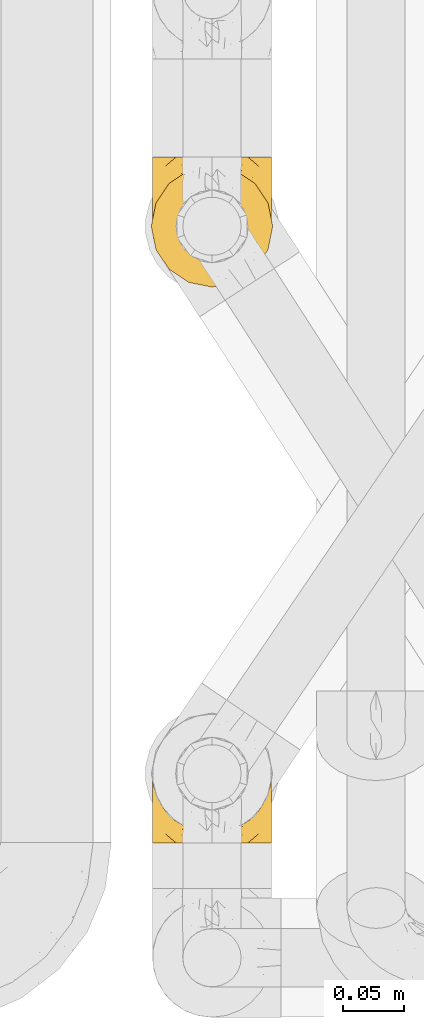
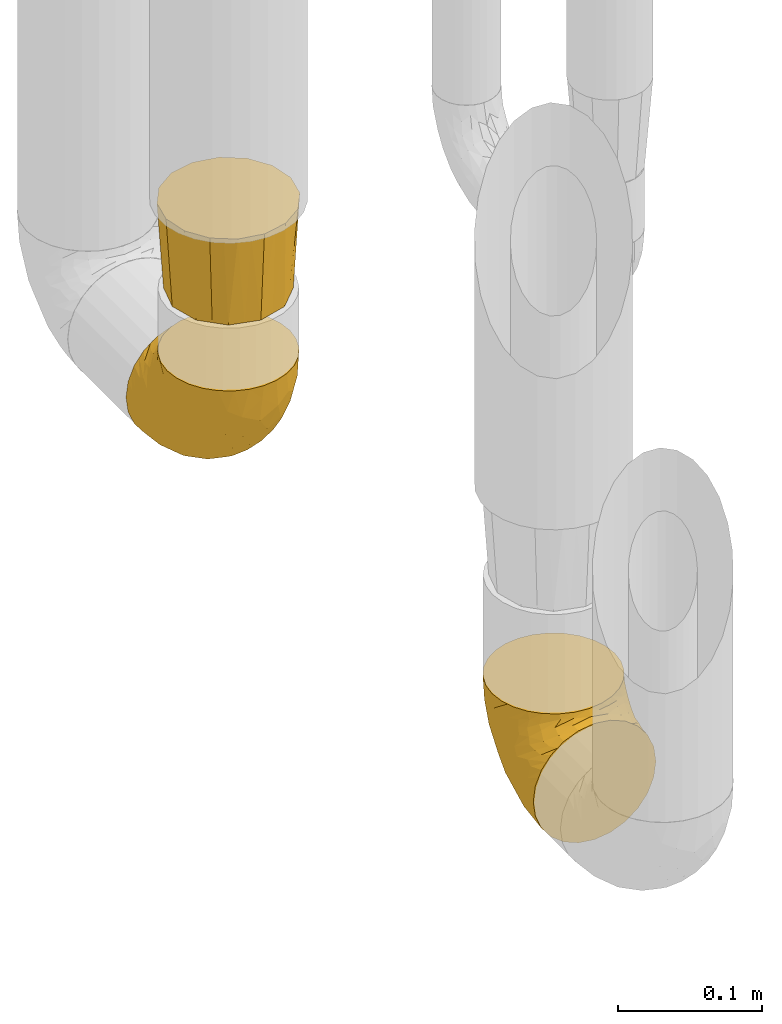
# One storey, part 380 of 827: 3 coverings.
"""IFC2X3 building model written with IfcOpenShell, lengths in millimetres."""

from ifc_helpers import new_model, entity, si_unit, converted_unit, derived_unit, direction, frame, origin, place, context, subcontext, project, spatial, faceted_brep, element, save


model = new_model("IFC2X3")

# Units and contexts
model_context = context("Model", 3, precision=0.01, world=origin(), true_north=direction((6.12303176911189e-17, 1.0)))
body_context = subcontext(model_context, "Body", "Model", "MODEL_VIEW")
ifc_project = project(units=[si_unit("LENGTHUNIT", "METRE", prefix="MILLI"), si_unit("AREAUNIT", "SQUARE_METRE"), si_unit("VOLUMEUNIT", "CUBIC_METRE"), converted_unit("PLANEANGLEUNIT", "DEGREE", entity("IfcRatioMeasure", 0.0174532925199433), si_unit("PLANEANGLEUNIT", "RADIAN"), dimensions=[0, 0, 0, 0, 0, 0, 0]), si_unit("MASSUNIT", "GRAM", prefix="KILO"), derived_unit("MASSDENSITYUNIT", [(si_unit("MASSUNIT", "GRAM", prefix="KILO"), 1), (si_unit("LENGTHUNIT", "METRE"), -3)]), derived_unit("MOMENTOFINERTIAUNIT", [(si_unit("LENGTHUNIT", "METRE"), 4)]), si_unit("TIMEUNIT", "SECOND"), si_unit("FREQUENCYUNIT", "HERTZ"), si_unit("THERMODYNAMICTEMPERATUREUNIT", "DEGREE_CELSIUS"), derived_unit("THERMALTRANSMITTANCEUNIT", [(si_unit("MASSUNIT", "GRAM", prefix="KILO"), 1), (si_unit("THERMODYNAMICTEMPERATUREUNIT", "KELVIN"), -1), (si_unit("TIMEUNIT", "SECOND"), -3)]), derived_unit("VOLUMETRICFLOWRATEUNIT", [(si_unit("LENGTHUNIT", "METRE"), 3), (si_unit("TIMEUNIT", "SECOND"), -1)]), derived_unit("MASSFLOWRATEUNIT", [(si_unit("MASSUNIT", "GRAM", prefix="KILO"), 1), (si_unit("TIMEUNIT", "SECOND"), -1)]), derived_unit("ROTATIONALFREQUENCYUNIT", [(si_unit("TIMEUNIT", "SECOND"), -1)]), si_unit("ELECTRICCURRENTUNIT", "AMPERE"), si_unit("ELECTRICVOLTAGEUNIT", "VOLT"), si_unit("POWERUNIT", "WATT"), si_unit("FORCEUNIT", "NEWTON", prefix="KILO"), si_unit("ILLUMINANCEUNIT", "LUX"), si_unit("LUMINOUSFLUXUNIT", "LUMEN"), si_unit("LUMINOUSINTENSITYUNIT", "CANDELA"), derived_unit("USERDEFINED", [(si_unit("MASSUNIT", "GRAM", prefix="KILO"), -1), (si_unit("LENGTHUNIT", "METRE"), -2), (si_unit("TIMEUNIT", "SECOND"), 3), (si_unit("LUMINOUSFLUXUNIT", "LUMEN"), 1)]), derived_unit("LINEARVELOCITYUNIT", [(si_unit("LENGTHUNIT", "METRE"), 1), (si_unit("TIMEUNIT", "SECOND"), -1)]), si_unit("PRESSUREUNIT", "PASCAL"), derived_unit("USERDEFINED", [(si_unit("LENGTHUNIT", "METRE"), -2), (si_unit("MASSUNIT", "GRAM", prefix="KILO"), 1), (si_unit("TIMEUNIT", "SECOND"), -2)]), derived_unit("LINEARFORCEUNIT", [(si_unit("MASSUNIT", "GRAM", prefix="KILO"), 1), (si_unit("LENGTHUNIT", "METRE"), 1), (si_unit("TIMEUNIT", "SECOND"), -2), (si_unit("LENGTHUNIT", "METRE"), -1)]), derived_unit("PLANARFORCEUNIT", [(si_unit("MASSUNIT", "GRAM", prefix="KILO"), 1), (si_unit("LENGTHUNIT", "METRE"), 1), (si_unit("TIMEUNIT", "SECOND"), -2), (si_unit("LENGTHUNIT", "METRE"), -2)])], contexts=[model_context])

# Site, building, storey
site_placement = place(None, origin())
site = spatial("IfcSite", under=ifc_project, at=site_placement, CompositionType="ELEMENT")
building_placement = place(site_placement, origin())
building = spatial("IfcBuilding", under=site, at=building_placement, CompositionType="ELEMENT")
storey_placement = place(building_placement, frame((0.0, 0.0, 28200.0)))
storey = spatial("IfcBuildingStorey", under=building, at=storey_placement, Name="08", CompositionType="ELEMENT", Elevation=28200.0)

# Coverings
covering_1_placement = place(storey_placement, frame((46642.04, 14188.78, 349.25)))
element("IfcCovering", 1, at=covering_1_placement, inside=storey, Name=":ADSK_", ObjectType=":ADSK_", PredefinedType="INSULATION", context=body_context, shape_type="Brep", body=[
    faceted_brep([(1.6, 50.75, 107.75), (2.83, 39.8, 107.75), (6.47, 29.41, 107.75), (12.32, 20.09, 107.75), (20.11, 12.31, 107.75), (29.43, 6.46, 107.75), (39.81, 2.83, 107.75), (50.75, 1.6, 107.75), (61.69, 2.83, 107.75), (72.08, 6.47, 107.75), (81.4, 12.32, 107.75), (89.18, 20.11, 107.75), (95.03, 29.43, 107.75), (98.66, 39.81, 107.75), (99.9, 50.75, 107.75), (99.25, 56.45, 107.75), (98.66, 61.69, 107.75), (96.84, 66.88, 107.75), (95.02, 72.08, 107.75), (89.17, 81.4, 107.75), (81.38, 89.18, 107.75), (72.06, 95.03, 107.75), (61.68, 98.66, 107.75), (50.75, 99.9, 107.75), (39.8, 98.66, 107.75), (29.41, 95.02, 107.75), (20.09, 89.17, 107.75), (12.31, 81.38, 107.75), (6.46, 72.06, 107.75), (4.64, 66.87, 107.75), (2.83, 61.68, 107.75), (2.24, 56.45, 107.75), (1.92, 53.6, 107.75), (63.47, 107.75, 98.22), (75.32, 107.75, 93.31), (80.41, 107.75, 89.4), (85.5, 107.75, 85.5), (89.4, 107.75, 80.41), (93.31, 107.75, 75.32), (95.77, 107.75, 69.39), (98.22, 107.75, 63.47), (99.14, 107.75, 56.48), (99.52, 107.75, 53.61), (99.9, 107.75, 50.75), (98.22, 107.75, 38.02), (93.31, 107.75, 26.17), (85.5, 107.75, 15.99), (75.32, 107.75, 8.18), (63.47, 107.75, 3.27), (50.75, 107.75, 1.6), (38.02, 107.75, 3.27), (26.17, 107.75, 8.18), (15.99, 107.75, 15.99), (8.18, 107.75, 26.17), (3.27, 107.75, 38.02), (1.6, 107.75, 50.75), (2.35, 107.75, 56.48), (3.27, 107.75, 63.47), (5.73, 107.75, 69.39), (8.18, 107.75, 75.32), (12.09, 107.75, 80.41), (15.99, 107.75, 85.5), (21.08, 107.75, 89.4), (26.17, 107.75, 93.31), (38.02, 107.75, 98.22), (50.75, 107.75, 99.9), (42.18, 39.38, 27.53), (28.42, 49.75, 25.32), (37.78, 57.38, 16.29), (50.75, 74.94, 6.79), (42.85, 85.97, 4.51), (50.75, 95.66, 3.51), (24.75, 67.82, 17.47), (33.81, 83.09, 7.6), (22.57, 89.16, 12.27), (7.18, 37.01, 70.89), (2.73, 43.46, 87.17), (3.09, 51.79, 67.3), (6.92, 85.58, 31.65), (11.58, 62.84, 33.58), (5.17, 62.77, 47.23), (2.71, 88.17, 43.26), (1.6, 85.93, 55.08), (1.6, 91.42, 53.99), (1.6, 96.91, 52.9), (1.6, 99.62, 52.36), (1.6, 102.33, 51.82), (14.18, 82.57, 21.5), (5.88, 32.75, 89.94), (41.06, 13.79, 60.45), (36.25, 6.77, 83.0), (28.62, 16.46, 64.79), (1.6, 55.08, 85.93), (1.6, 58.17, 81.31), (1.6, 61.26, 76.69), (1.6, 64.35, 72.06), (1.6, 67.44, 67.44), (10.85, 24.18, 88.74), (38.35, 23.37, 45.98), (9.6, 49.76, 47.13), (26.24, 9.84, 89.4), (50.75, 3.51, 95.66), (19.31, 55.75, 28.5), (16.41, 42.34, 42.81), (24.56, 37.78, 38.28), (50.75, 21.87, 45.35), (50.75, 33.61, 33.61), (18.47, 17.1, 82.57), (1.6, 51.28, 105.04), (1.6, 51.82, 102.33), (1.6, 52.9, 96.91), (1.6, 53.99, 91.42), (14.36, 28.01, 65.92), (20.64, 28.99, 53.11), (2.32, 69.9, 54.37), (50.75, 6.79, 74.94), (1.6, 72.06, 64.35), (1.6, 76.69, 61.26), (1.6, 81.31, 58.17), (50.75, 45.35, 21.87), (33.88, 34.79, 34.79), (29.24, 25.72, 48.48), (50.75, 14.33, 60.15), (50.75, 60.15, 14.33), (2.8, 62.38, 99.07), (2.48, 100.57, 60.55), (2.7, 91.06, 64.18), (3.2, 97.66, 64.36), (32.98, 97.55, 103.17), (24.67, 93.65, 101.69), (2.95, 66.85, 87.75), (2.19, 61.93, 89.38), (17.92, 101.4, 88.34), (12.02, 100.07, 82.14), (25.73, 101.36, 94.51), (16.63, 95.94, 89.64), (25.6, 96.3, 98.41), (36.72, 101.98, 99.71), (10.66, 85.88, 89.37), (6.87, 78.88, 88.21), (11.12, 82.8, 95.2), (10.31, 102.58, 79.14), (12.84, 82.88, 101.22), (17.38, 88.57, 99.41), (9.74, 88.67, 84.72), (4.63, 69.08, 97.47), (50.75, 102.19, 102.19), (42.52, 100.06, 104.02), (3.12, 70.56, 82.66), (17.58, 91.07, 95.42), (3.97, 77.56, 78.67), (5.94, 96.59, 72.69), (2.73, 86.38, 66.46), (6.23, 91.79, 75.3), (3.45, 81.71, 72.74), (10.84, 94.11, 82.93), (7.98, 76.09, 99.27), (7.33, 76.91, 93.51), (2.39, 81.44, 67.35), (75.76, 101.37, 94.51), (90.65, 94.12, 82.94), (83.57, 101.41, 88.33), (84.85, 95.96, 89.64), (71.05, 96.22, 103.62), (98.54, 66.85, 87.74), (99.3, 61.94, 89.38), (99.9, 58.17, 81.31), (96.86, 69.1, 97.47), (84.1, 88.58, 99.41), (99.9, 96.91, 52.9), (99.9, 102.33, 51.82), (99.9, 105.04, 51.28), (88.63, 82.9, 101.21), (90.36, 82.82, 95.19), (98.29, 97.66, 64.36), (95.55, 96.59, 72.69), (89.47, 100.07, 82.13), (95.26, 91.79, 75.3), (91.18, 102.58, 79.14), (93.49, 76.13, 99.28), (94.15, 76.93, 93.51), (99.01, 100.57, 60.55), (98.76, 86.38, 66.46), (98.85, 90.86, 63.96), (99.9, 52.9, 96.91), (98.69, 62.39, 99.06), (64.78, 101.98, 99.7), (99.9, 91.42, 53.99), (99.9, 85.93, 55.08), (62.91, 99.49, 103.3), (99.9, 51.82, 102.33), (99.9, 52.36, 99.62), (99.9, 61.26, 76.69), (98.37, 70.56, 82.66), (83.9, 91.09, 95.42), (99.9, 64.35, 72.06), (97.51, 77.6, 78.68), (94.62, 78.89, 88.2), (98.04, 81.71, 72.75), (91.73, 88.69, 84.74), (99.9, 53.99, 91.42), (99.9, 55.08, 85.93), (75.87, 96.31, 98.41), (90.83, 85.9, 89.37), (99.1, 81.45, 67.35), (99.9, 76.69, 61.26), (99.9, 81.31, 58.17), (99.9, 72.06, 64.35), (99.9, 67.44, 67.44), (99.09, 69.6, 54.08), (58.64, 85.97, 4.51), (87.31, 82.57, 21.5), (89.93, 63.16, 33.43), (82.22, 55.81, 28.5), (76.74, 67.81, 17.47), (73.12, 49.73, 25.36), (95.54, 32.55, 90.18), (98.7, 43.23, 86.97), (98.79, 88.17, 43.26), (63.71, 57.38, 16.29), (67.68, 83.08, 7.6), (78.92, 89.16, 12.27), (94.57, 85.58, 31.65), (72.88, 16.46, 64.79), (65.25, 6.77, 83.0), (60.44, 13.8, 60.44), (76.94, 37.71, 38.35), (67.61, 34.8, 34.8), (94.38, 36.83, 71.54), (59.31, 39.38, 27.53), (83.03, 17.12, 82.57), (90.66, 24.19, 88.74), (80.8, 28.89, 53.19), (72.22, 25.69, 48.49), (98.39, 51.77, 67.28), (92.31, 45.66, 52.32), (63.11, 23.39, 45.94), (75.27, 9.85, 89.4), (87.15, 28.11, 65.75), (96.03, 62.27, 46.73), (85.1, 42.35, 42.82)], [[[0, 1, 2, 3, 4, 5, 6, 7, 8, 9, 10, 11, 12, 13, 14, 15, 16, 17, 18, 19, 20, 21, 22, 23, 24, 25, 26, 27, 28, 29, 30, 31, 32]], [[33, 34, 35, 36, 37, 38, 39, 40, 41, 42, 43, 44, 45, 46, 47, 48, 49, 50, 51, 52, 53, 54, 55, 56, 57, 58, 59, 60, 61, 62, 63, 64, 65]], [[66, 67, 68]], [[69, 70, 71]], [[68, 72, 73]], [[73, 72, 74]], [[75, 76, 77]], [[78, 79, 80]], [[51, 50, 73]], [[81, 82, 83, 84, 85, 86, 55]], [[52, 87, 53]], [[74, 52, 51]], [[2, 1, 88]], [[89, 90, 91]], [[77, 92, 93, 94, 95, 96]], [[55, 54, 81]], [[78, 53, 87]], [[5, 90, 6]], [[88, 76, 75]], [[97, 3, 2]], [[89, 91, 98]], [[99, 80, 79]], [[90, 5, 100]], [[74, 87, 52]], [[100, 5, 4]], [[90, 101, 6]], [[79, 102, 103]], [[102, 67, 104]], [[105, 98, 106]], [[107, 4, 3]], [[76, 0, 108, 109, 110, 111, 92]], [[107, 112, 113]], [[114, 77, 96]], [[89, 115, 90]], [[114, 96, 116, 117, 118, 82]], [[75, 97, 88]], [[119, 66, 68]], [[50, 71, 70]], [[100, 91, 90]], [[99, 77, 80]], [[102, 104, 103]], [[97, 107, 3]], [[80, 81, 78]], [[107, 97, 112]], [[68, 73, 70]], [[66, 98, 120]], [[78, 81, 54]], [[114, 81, 80]], [[53, 78, 54]], [[78, 87, 79]], [[102, 87, 72]], [[79, 103, 99]], [[4, 107, 100]], [[91, 100, 107]], [[88, 97, 2]], [[112, 97, 75]], [[99, 112, 75]], [[103, 104, 113]], [[91, 121, 98]], [[89, 105, 122, 115]], [[101, 90, 115]], [[101, 7, 6]], [[88, 1, 76]], [[0, 76, 1]], [[92, 77, 76]], [[73, 74, 51]], [[87, 74, 72]], [[81, 114, 82]], [[77, 114, 80]], [[87, 102, 79]], [[67, 102, 72]], [[68, 67, 72]], [[67, 120, 104]], [[120, 121, 104]], [[104, 121, 113]], [[121, 120, 98]], [[91, 107, 113]], [[91, 113, 121]], [[103, 113, 112]], [[106, 98, 66]], [[105, 89, 98]], [[106, 66, 119]], [[67, 66, 120]], [[68, 69, 123, 119]], [[50, 49, 71]], [[50, 70, 73]], [[112, 99, 103]], [[77, 99, 75]], [[69, 68, 70]], [[29, 124, 110]], [[84, 83, 125]], [[126, 82, 118]], [[59, 58, 127]], [[25, 128, 129]], [[130, 93, 131]], [[132, 62, 133]], [[134, 135, 136]], [[137, 65, 64]], [[64, 134, 137]], [[138, 139, 140]], [[111, 110, 124, 92]], [[134, 136, 137]], [[134, 64, 63]], [[141, 61, 60]], [[125, 58, 57]], [[142, 143, 140]], [[142, 26, 143]], [[127, 83, 82]], [[28, 124, 29]], [[108, 0, 32, 31, 30, 110, 109]], [[30, 29, 110]], [[135, 144, 138]], [[28, 145, 124]], [[57, 56, 55, 86, 85, 84]], [[146, 147, 23]], [[24, 23, 147]], [[25, 143, 26]], [[95, 94, 148]], [[24, 128, 25]], [[149, 138, 143]], [[124, 145, 131]], [[127, 58, 125]], [[150, 148, 139]], [[127, 126, 151]], [[151, 59, 127]], [[152, 151, 126]], [[153, 154, 155]], [[153, 133, 141]], [[145, 28, 27]], [[142, 156, 27]], [[157, 148, 130]], [[61, 133, 62]], [[134, 132, 135]], [[147, 128, 24]], [[65, 137, 146]], [[146, 137, 147]], [[128, 137, 136]], [[137, 128, 147]], [[128, 136, 129]], [[149, 129, 136]], [[25, 129, 143]], [[158, 152, 117]], [[152, 118, 117]], [[153, 151, 152]], [[158, 116, 154]], [[144, 150, 138]], [[153, 152, 158]], [[133, 153, 155]], [[133, 155, 132]], [[60, 151, 141]], [[135, 132, 155]], [[134, 63, 132]], [[144, 135, 155]], [[135, 138, 149]], [[155, 154, 144]], [[150, 154, 96]], [[154, 150, 144]], [[148, 94, 130]], [[82, 126, 127]], [[118, 152, 126]], [[150, 96, 95]], [[139, 148, 157]], [[150, 95, 148]], [[93, 92, 131]], [[130, 145, 156]], [[130, 94, 93]], [[84, 125, 57]], [[127, 125, 83]], [[140, 139, 157]], [[150, 139, 138]], [[140, 157, 142]], [[138, 140, 143]], [[156, 142, 157]], [[27, 26, 142]], [[130, 156, 157]], [[145, 27, 156]], [[132, 63, 62]], [[124, 131, 92]], [[130, 131, 145]], [[129, 149, 143]], [[135, 149, 136]], [[141, 133, 61]], [[60, 59, 151]], [[141, 151, 153]], [[116, 96, 154]], [[153, 158, 154]], [[158, 117, 116]], [[34, 33, 159]], [[160, 161, 162]], [[22, 21, 163]], [[164, 165, 166]], [[19, 18, 167]], [[168, 21, 20]], [[42, 41, 40, 169, 170, 171, 43]], [[172, 173, 168]], [[174, 38, 175]], [[176, 177, 178]], [[179, 164, 180]], [[40, 181, 169]], [[182, 183, 175]], [[17, 184, 185]], [[65, 146, 186]], [[187, 174, 188]], [[23, 22, 189]], [[174, 39, 38]], [[15, 14, 190, 191, 184, 16]], [[181, 40, 39]], [[192, 193, 164]], [[194, 163, 168]], [[33, 186, 159]], [[180, 173, 172]], [[195, 196, 193]], [[18, 185, 167]], [[173, 180, 197]], [[198, 199, 196]], [[200, 201, 185, 184]], [[184, 17, 16]], [[18, 17, 185]], [[202, 159, 186]], [[194, 168, 203]], [[189, 163, 202]], [[204, 205, 182]], [[187, 181, 174]], [[160, 177, 176]], [[206, 183, 182]], [[206, 182, 205]], [[201, 165, 185]], [[165, 164, 167]], [[172, 179, 180]], [[202, 194, 162]], [[176, 161, 160]], [[65, 186, 33]], [[163, 189, 22]], [[175, 177, 182]], [[174, 183, 188]], [[177, 198, 204]], [[199, 160, 162]], [[198, 207, 204]], [[175, 38, 37]], [[198, 177, 160]], [[178, 177, 175]], [[176, 35, 161]], [[34, 159, 161]], [[162, 161, 159]], [[202, 162, 159]], [[199, 162, 203]], [[196, 199, 203]], [[198, 160, 199]], [[193, 197, 180]], [[208, 198, 196]], [[188, 183, 206]], [[175, 183, 174]], [[193, 192, 195]], [[195, 208, 196]], [[197, 196, 203]], [[180, 164, 193]], [[168, 163, 21]], [[166, 165, 201]], [[166, 192, 164]], [[189, 202, 186]], [[186, 146, 189]], [[23, 189, 146]], [[174, 181, 39]], [[169, 181, 187]], [[196, 197, 193]], [[173, 203, 168]], [[203, 173, 197]], [[172, 168, 20]], [[20, 19, 172]], [[179, 172, 19]], [[19, 167, 179]], [[164, 179, 167]], [[35, 176, 36]], [[35, 34, 161]], [[185, 165, 167]], [[162, 194, 203]], [[163, 194, 202]], [[176, 178, 36]], [[37, 36, 178]], [[175, 37, 178]], [[177, 204, 182]], [[207, 198, 208]], [[207, 205, 204]], [[209, 188, 206, 205, 207, 208]], [[48, 210, 71]], [[211, 212, 213]], [[214, 213, 215]], [[216, 217, 13]], [[218, 43, 171, 170, 169, 187, 188]], [[219, 220, 214]], [[47, 46, 221]], [[210, 48, 220]], [[211, 222, 212]], [[222, 45, 44]], [[221, 220, 47]], [[47, 220, 48]], [[221, 211, 214]], [[223, 224, 225]], [[211, 46, 45]], [[226, 227, 215]], [[43, 218, 44]], [[217, 216, 228]], [[219, 215, 229]], [[14, 13, 217]], [[224, 9, 8]], [[10, 230, 11]], [[11, 231, 12]], [[232, 223, 233]], [[234, 208, 195, 192, 166, 201]], [[235, 234, 228]], [[222, 44, 218]], [[106, 229, 236]], [[224, 237, 9]], [[231, 238, 228]], [[9, 237, 10]], [[115, 224, 101]], [[239, 234, 235]], [[231, 11, 230]], [[223, 230, 237]], [[224, 8, 101]], [[223, 236, 233]], [[225, 115, 122, 105]], [[216, 12, 231]], [[209, 234, 239]], [[210, 219, 69]], [[219, 214, 215]], [[229, 119, 219]], [[209, 218, 188]], [[239, 212, 222]], [[239, 222, 218]], [[45, 222, 211]], [[235, 212, 239]], [[213, 212, 240]], [[223, 237, 224]], [[230, 10, 237]], [[238, 231, 230]], [[216, 231, 228]], [[232, 230, 223]], [[235, 238, 240]], [[115, 225, 224]], [[233, 236, 227]], [[8, 7, 101]], [[234, 209, 208]], [[218, 209, 239]], [[217, 228, 234]], [[13, 12, 216]], [[234, 201, 217]], [[217, 201, 200, 184, 191, 190, 14]], [[211, 221, 46]], [[220, 221, 214]], [[71, 210, 69]], [[71, 49, 48]], [[219, 210, 220]], [[226, 215, 213]], [[211, 213, 214]], [[226, 213, 240]], [[215, 227, 229]], [[232, 240, 238]], [[233, 227, 226]], [[232, 233, 226]], [[236, 223, 225]], [[240, 232, 226]], [[232, 238, 230]], [[225, 105, 236]], [[236, 105, 106]], [[236, 229, 227]], [[123, 69, 219, 119]], [[106, 119, 229]], [[238, 235, 228]], [[212, 235, 240]]]),
])
covering_2_placement = place(storey_placement, frame((46641.19, 14187.93, 510.0)))
element("IfcCovering", 2, at=covering_2_placement, inside=storey, Name=":ADSK_", ObjectType=":ADSK_", PredefinedType="INSULATION", context=body_context, shape_type="Brep", body=[
    faceted_brep([(70.73, 97.79, 76.0), (61.16, 99.69, 76.0), (51.6, 101.6, 76.0), (42.03, 99.69, 76.0), (32.46, 97.79, 76.0), (24.35, 92.37, 76.0), (16.24, 86.95, 76.0), (10.82, 78.84, 76.0), (5.4, 70.73, 76.0), (3.5, 61.16, 76.0), (1.6, 51.6, 76.0), (3.5, 42.03, 76.0), (5.4, 32.46, 76.0), (10.82, 24.35, 76.0), (16.24, 16.24, 76.0), (24.35, 10.82, 76.0), (32.46, 5.4, 76.0), (42.03, 3.5, 76.0), (51.6, 1.6, 76.0), (61.16, 3.5, 76.0), (70.73, 5.4, 76.0), (78.84, 10.82, 76.0), (86.95, 16.24, 76.0), (92.37, 24.35, 76.0), (97.79, 32.46, 76.0), (99.69, 42.03, 76.0), (101.6, 51.6, 76.0), (99.69, 61.16, 76.0), (97.79, 70.73, 76.0), (92.37, 78.84, 76.0), (86.95, 86.95, 76.0), (78.84, 92.37, 76.0), (12.62, 74.1, 0.0), (20.86, 82.33, 0.0), (29.1, 90.57, 0.0), (40.35, 93.58, 0.0), (51.6, 96.6, 0.0), (62.85, 93.58, 0.0), (74.1, 90.57, 0.0), (82.33, 82.33, 0.0), (90.57, 74.1, 0.0), (93.58, 62.85, 0.0), (96.6, 51.6, 0.0), (93.58, 40.35, 0.0), (90.57, 29.1, 0.0), (82.33, 20.86, 0.0), (74.1, 12.62, 0.0), (62.85, 9.61, 0.0), (51.6, 6.6, 0.0), (40.35, 9.61, 0.0), (29.1, 12.62, 0.0), (20.86, 20.86, 0.0), (12.62, 29.1, 0.0), (9.61, 40.35, 0.0), (6.6, 51.6, 0.0), (9.61, 62.85, 0.0)], [[[0, 1, 2, 3, 4, 5, 6, 7, 8, 9, 10, 11, 12, 13, 14, 15, 16, 17, 18, 19, 20, 21, 22, 23, 24, 25, 26, 27, 28, 29, 30, 31]], [[32, 33, 34, 35, 36, 37, 38, 39, 40, 41, 42, 43, 44, 45, 46, 47, 48, 49, 50, 51, 52, 53, 54, 55]], [[11, 10, 54]], [[50, 15, 51]], [[51, 13, 52]], [[54, 53, 11]], [[14, 51, 15]], [[17, 48, 18]], [[13, 12, 52]], [[13, 51, 14]], [[48, 17, 49]], [[53, 52, 12]], [[53, 12, 11]], [[16, 50, 49]], [[17, 16, 49]], [[50, 16, 15]], [[19, 18, 48]], [[44, 23, 45]], [[45, 21, 46]], [[48, 47, 19]], [[22, 45, 23]], [[25, 42, 26]], [[21, 20, 46]], [[21, 45, 22]], [[42, 25, 43]], [[47, 46, 20]], [[47, 20, 19]], [[24, 44, 43]], [[25, 24, 43]], [[44, 24, 23]], [[27, 26, 42]], [[38, 31, 39]], [[39, 29, 40]], [[42, 41, 27]], [[30, 39, 31]], [[1, 36, 2]], [[29, 28, 40]], [[29, 39, 30]], [[36, 1, 37]], [[41, 40, 28]], [[41, 28, 27]], [[0, 38, 37]], [[1, 0, 37]], [[38, 0, 31]], [[3, 2, 36]], [[32, 7, 33]], [[33, 5, 34]], [[36, 35, 3]], [[6, 33, 7]], [[9, 54, 10]], [[5, 4, 34]], [[5, 33, 6]], [[54, 9, 55]], [[35, 34, 4]], [[35, 4, 3]], [[8, 32, 55]], [[9, 8, 55]], [[32, 8, 7]]]),
])
covering_3_placement = place(storey_placement, frame((46642.04, 13729.91, 349.25)))
element("IfcCovering", 3, at=covering_3_placement, inside=storey, Name=":ADSK_", ObjectType=":ADSK_", PredefinedType="INSULATION", context=body_context, shape_type="Brep", body=[
    faceted_brep([(99.9, 58.6, 107.75), (98.66, 69.54, 107.75), (95.02, 79.93, 107.75), (89.17, 89.25, 107.75), (81.38, 97.03, 107.75), (72.06, 102.88, 107.75), (61.68, 106.51, 107.75), (50.75, 107.75, 107.75), (39.8, 106.51, 107.75), (29.41, 102.87, 107.75), (20.09, 97.02, 107.75), (12.31, 89.23, 107.75), (6.46, 79.91, 107.75), (2.83, 69.53, 107.75), (1.6, 58.6, 107.75), (2.24, 52.89, 107.75), (2.83, 47.65, 107.75), (4.65, 42.46, 107.75), (6.47, 37.26, 107.75), (12.32, 27.94, 107.75), (20.11, 20.16, 107.75), (29.43, 14.31, 107.75), (39.81, 10.68, 107.75), (50.75, 9.45, 107.75), (61.69, 10.68, 107.75), (72.08, 14.32, 107.75), (81.4, 20.17, 107.75), (89.18, 27.96, 107.75), (95.03, 37.28, 107.75), (96.85, 42.47, 107.75), (98.66, 47.66, 107.75), (99.25, 52.89, 107.75), (99.57, 55.75, 107.75), (38.02, 1.6, 98.22), (26.17, 1.6, 93.31), (21.08, 1.6, 89.4), (15.99, 1.6, 85.5), (12.09, 1.6, 80.41), (8.18, 1.6, 75.32), (5.73, 1.6, 69.39), (3.27, 1.6, 63.47), (2.35, 1.6, 56.48), (1.97, 1.6, 53.61), (1.6, 1.6, 50.75), (3.27, 1.6, 38.02), (8.18, 1.6, 26.17), (15.99, 1.6, 15.99), (26.17, 1.6, 8.18), (38.02, 1.6, 3.27), (50.75, 1.6, 1.6), (63.47, 1.6, 3.27), (75.32, 1.6, 8.18), (85.5, 1.6, 15.99), (93.31, 1.6, 26.17), (98.22, 1.6, 38.02), (99.9, 1.6, 50.75), (99.14, 1.6, 56.48), (98.22, 1.6, 63.47), (95.77, 1.6, 69.39), (93.31, 1.6, 75.32), (89.4, 1.6, 80.41), (85.5, 1.6, 85.5), (80.41, 1.6, 89.4), (75.32, 1.6, 93.31), (63.47, 1.6, 98.22), (50.75, 1.6, 99.9), (59.31, 69.96, 27.53), (73.08, 59.59, 25.32), (63.72, 51.96, 16.29), (50.75, 34.4, 6.79), (58.64, 23.37, 4.51), (50.75, 13.68, 3.51), (76.74, 41.52, 17.47), (67.68, 26.26, 7.6), (78.92, 20.18, 12.27), (94.31, 72.33, 70.89), (98.76, 65.88, 87.17), (98.4, 57.55, 67.3), (94.57, 23.76, 31.65), (89.91, 46.5, 33.58), (96.32, 46.57, 47.23), (98.79, 21.17, 43.26), (99.9, 23.41, 55.08), (99.9, 17.92, 53.99), (99.9, 12.43, 52.9), (99.9, 9.72, 52.36), (99.9, 7.01, 51.82), (87.31, 26.77, 21.5), (95.61, 76.59, 89.94), (60.43, 95.55, 60.45), (65.24, 102.57, 83.0), (72.87, 92.89, 64.79), (99.9, 54.26, 85.93), (99.9, 51.17, 81.31), (99.9, 48.08, 76.69), (99.9, 44.99, 72.06), (99.9, 41.9, 67.44), (90.65, 85.16, 88.74), (63.14, 85.97, 45.98), (91.89, 59.58, 47.13), (75.25, 99.5, 89.4), (50.75, 105.83, 95.66), (82.18, 53.59, 28.5), (85.08, 67.0, 42.81), (76.93, 71.56, 38.28), (50.75, 87.47, 45.35), (50.75, 75.73, 33.61), (83.02, 92.24, 82.57), (99.9, 58.06, 105.04), (99.9, 57.52, 102.33), (99.9, 56.44, 96.91), (99.9, 55.35, 91.42), (87.13, 81.33, 65.92), (80.85, 80.35, 53.11), (99.17, 39.44, 54.37), (50.75, 102.55, 74.94), (99.9, 37.28, 64.35), (99.9, 32.65, 61.26), (99.9, 28.03, 58.17), (50.75, 63.99, 21.87), (67.61, 74.55, 34.79), (72.25, 83.62, 48.48), (50.75, 95.01, 60.15), (50.75, 49.19, 14.33), (98.69, 46.96, 99.07), (99.01, 8.77, 60.55), (98.79, 18.28, 64.18), (98.29, 11.68, 64.36), (68.51, 11.79, 103.17), (76.82, 15.69, 101.69), (98.54, 42.49, 87.75), (99.3, 47.41, 89.38), (83.57, 7.94, 88.34), (89.47, 9.27, 82.14), (75.76, 7.98, 94.51), (84.86, 13.4, 89.64), (75.89, 13.04, 98.41), (64.77, 7.36, 99.71), (90.83, 23.46, 89.37), (94.62, 30.46, 88.21), (90.37, 26.54, 95.2), (91.18, 6.76, 79.14), (88.65, 26.46, 101.22), (84.11, 20.77, 99.41), (91.75, 20.68, 84.72), (96.86, 40.26, 97.47), (50.75, 7.15, 102.19), (58.97, 9.28, 104.02), (98.37, 38.78, 82.66), (83.91, 18.27, 95.42), (97.52, 31.78, 78.67), (95.55, 12.75, 72.69), (98.76, 22.96, 66.46), (95.26, 17.55, 75.3), (98.04, 27.63, 72.74), (90.65, 15.23, 82.93), (93.51, 33.25, 99.27), (94.16, 32.43, 93.51), (99.1, 27.9, 67.35), (25.73, 7.97, 94.51), (10.84, 15.22, 82.94), (17.92, 7.93, 88.33), (16.64, 13.38, 89.64), (30.44, 13.12, 103.62), (2.95, 42.49, 87.74), (2.19, 47.4, 89.38), (1.6, 51.17, 81.31), (4.63, 40.24, 97.47), (17.39, 20.76, 99.41), (1.6, 12.43, 52.9), (1.6, 7.01, 51.82), (1.6, 4.31, 51.28), (12.86, 26.44, 101.21), (11.13, 26.52, 95.19), (3.2, 11.68, 64.36), (5.94, 12.75, 72.69), (12.02, 9.27, 82.13), (6.23, 17.55, 75.3), (10.31, 6.76, 79.14), (8.0, 33.21, 99.28), (7.34, 32.41, 93.51), (2.48, 8.77, 60.55), (2.73, 22.96, 66.46), (2.64, 18.48, 63.96), (1.6, 56.44, 96.91), (2.8, 46.95, 99.06), (36.71, 7.36, 99.7), (1.6, 17.92, 53.99), (1.6, 23.41, 55.08), (38.59, 9.85, 103.3), (1.6, 57.52, 102.33), (1.6, 56.98, 99.62), (1.6, 48.08, 76.69), (3.12, 38.78, 82.66), (17.59, 18.25, 95.42), (1.6, 44.99, 72.06), (3.98, 31.74, 78.68), (6.87, 30.45, 88.2), (3.45, 27.63, 72.75), (9.76, 20.65, 84.74), (1.6, 55.35, 91.42), (1.6, 54.26, 85.93), (25.62, 13.03, 98.41), (10.67, 23.44, 89.37), (2.39, 27.9, 67.35), (1.6, 32.65, 61.26), (1.6, 28.03, 58.17), (1.6, 37.28, 64.35), (1.6, 41.9, 67.44), (2.4, 39.74, 54.08), (42.85, 23.37, 4.51), (14.18, 26.77, 21.5), (11.56, 46.18, 33.43), (19.27, 53.54, 28.5), (24.75, 41.53, 17.47), (28.37, 59.61, 25.36), (5.95, 76.79, 90.18), (2.79, 66.11, 86.97), (2.71, 21.17, 43.26), (37.78, 51.96, 16.29), (33.81, 26.26, 7.6), (22.57, 20.18, 12.27), (6.92, 23.76, 31.65), (28.61, 92.88, 64.79), (36.24, 102.57, 83.0), (41.05, 95.54, 60.44), (24.55, 71.63, 38.35), (33.88, 74.55, 34.8), (7.11, 72.51, 71.54), (42.18, 69.96, 27.53), (18.46, 92.23, 82.57), (10.84, 85.15, 88.74), (20.69, 80.45, 53.19), (29.27, 83.65, 48.49), (3.1, 57.57, 67.28), (9.18, 63.68, 52.32), (38.38, 85.95, 45.94), (26.23, 99.49, 89.4), (14.34, 81.23, 65.75), (5.46, 47.07, 46.73), (16.39, 66.99, 42.82)], [[[0, 1, 2, 3, 4, 5, 6, 7, 8, 9, 10, 11, 12, 13, 14, 15, 16, 17, 18, 19, 20, 21, 22, 23, 24, 25, 26, 27, 28, 29, 30, 31, 32]], [[33, 34, 35, 36, 37, 38, 39, 40, 41, 42, 43, 44, 45, 46, 47, 48, 49, 50, 51, 52, 53, 54, 55, 56, 57, 58, 59, 60, 61, 62, 63, 64, 65]], [[66, 67, 68]], [[69, 70, 71]], [[68, 72, 73]], [[73, 72, 74]], [[75, 76, 77]], [[78, 79, 80]], [[51, 50, 73]], [[81, 82, 83, 84, 85, 86, 55]], [[52, 87, 53]], [[74, 52, 51]], [[2, 1, 88]], [[89, 90, 91]], [[77, 92, 93, 94, 95, 96]], [[55, 54, 81]], [[78, 53, 87]], [[5, 90, 6]], [[88, 76, 75]], [[97, 3, 2]], [[89, 91, 98]], [[99, 80, 79]], [[90, 5, 100]], [[74, 87, 52]], [[100, 5, 4]], [[90, 101, 6]], [[79, 102, 103]], [[102, 67, 104]], [[105, 98, 106]], [[107, 4, 3]], [[76, 0, 108, 109, 110, 111, 92]], [[107, 112, 113]], [[114, 77, 96]], [[89, 115, 90]], [[114, 96, 116, 117, 118, 82]], [[75, 97, 88]], [[119, 66, 68]], [[50, 71, 70]], [[100, 91, 90]], [[99, 77, 80]], [[102, 104, 103]], [[97, 107, 3]], [[80, 81, 78]], [[107, 97, 112]], [[68, 73, 70]], [[66, 98, 120]], [[78, 81, 54]], [[114, 81, 80]], [[53, 78, 54]], [[78, 87, 79]], [[102, 87, 72]], [[79, 103, 99]], [[4, 107, 100]], [[91, 100, 107]], [[88, 97, 2]], [[112, 97, 75]], [[99, 112, 75]], [[103, 104, 113]], [[91, 121, 98]], [[89, 105, 122, 115]], [[101, 90, 115]], [[101, 7, 6]], [[88, 1, 76]], [[0, 76, 1]], [[92, 77, 76]], [[73, 74, 51]], [[87, 74, 72]], [[81, 114, 82]], [[77, 114, 80]], [[87, 102, 79]], [[67, 102, 72]], [[68, 67, 72]], [[67, 120, 104]], [[120, 121, 104]], [[104, 121, 113]], [[121, 120, 98]], [[91, 107, 113]], [[91, 113, 121]], [[103, 113, 112]], [[106, 98, 66]], [[105, 89, 98]], [[106, 66, 119]], [[67, 66, 120]], [[68, 69, 123, 119]], [[50, 49, 71]], [[50, 70, 73]], [[112, 99, 103]], [[77, 99, 75]], [[69, 68, 70]], [[29, 124, 110]], [[84, 83, 125]], [[126, 82, 118]], [[59, 58, 127]], [[25, 128, 129]], [[130, 93, 131]], [[132, 62, 133]], [[134, 135, 136]], [[137, 65, 64]], [[64, 134, 137]], [[138, 139, 140]], [[111, 110, 124, 92]], [[134, 136, 137]], [[134, 64, 63]], [[141, 61, 60]], [[125, 58, 57]], [[142, 143, 140]], [[142, 26, 143]], [[127, 83, 82]], [[28, 124, 29]], [[108, 0, 32, 31, 30, 110, 109]], [[30, 29, 110]], [[135, 144, 138]], [[28, 145, 124]], [[57, 56, 55, 86, 85, 84]], [[146, 147, 23]], [[24, 23, 147]], [[25, 143, 26]], [[95, 94, 148]], [[24, 128, 25]], [[149, 138, 143]], [[124, 145, 131]], [[127, 58, 125]], [[150, 148, 139]], [[127, 126, 151]], [[151, 59, 127]], [[152, 151, 126]], [[153, 154, 155]], [[153, 133, 141]], [[145, 28, 27]], [[142, 156, 27]], [[157, 148, 130]], [[61, 133, 62]], [[134, 132, 135]], [[147, 128, 24]], [[65, 137, 146]], [[146, 137, 147]], [[128, 137, 136]], [[137, 128, 147]], [[128, 136, 129]], [[149, 129, 136]], [[25, 129, 143]], [[158, 152, 117]], [[152, 118, 117]], [[153, 151, 152]], [[158, 116, 154]], [[144, 150, 138]], [[153, 152, 158]], [[133, 153, 155]], [[133, 155, 132]], [[60, 151, 141]], [[135, 132, 155]], [[134, 63, 132]], [[144, 135, 155]], [[135, 138, 149]], [[155, 154, 144]], [[150, 154, 96]], [[154, 150, 144]], [[148, 94, 130]], [[82, 126, 127]], [[118, 152, 126]], [[150, 96, 95]], [[139, 148, 157]], [[150, 95, 148]], [[93, 92, 131]], [[130, 145, 156]], [[130, 94, 93]], [[84, 125, 57]], [[127, 125, 83]], [[140, 139, 157]], [[150, 139, 138]], [[140, 157, 142]], [[138, 140, 143]], [[156, 142, 157]], [[27, 26, 142]], [[130, 156, 157]], [[145, 27, 156]], [[132, 63, 62]], [[124, 131, 92]], [[130, 131, 145]], [[129, 149, 143]], [[135, 149, 136]], [[141, 133, 61]], [[60, 59, 151]], [[141, 151, 153]], [[116, 96, 154]], [[153, 158, 154]], [[158, 117, 116]], [[34, 33, 159]], [[160, 161, 162]], [[22, 21, 163]], [[164, 165, 166]], [[19, 18, 167]], [[168, 21, 20]], [[42, 41, 40, 169, 170, 171, 43]], [[172, 173, 168]], [[174, 38, 175]], [[176, 177, 178]], [[179, 164, 180]], [[40, 181, 169]], [[182, 183, 175]], [[17, 184, 185]], [[65, 146, 186]], [[187, 174, 188]], [[23, 22, 189]], [[174, 39, 38]], [[15, 14, 190, 191, 184, 16]], [[181, 40, 39]], [[192, 193, 164]], [[194, 163, 168]], [[33, 186, 159]], [[180, 173, 172]], [[195, 196, 193]], [[18, 185, 167]], [[173, 180, 197]], [[198, 199, 196]], [[200, 201, 185, 184]], [[184, 17, 16]], [[18, 17, 185]], [[202, 159, 186]], [[194, 168, 203]], [[189, 163, 202]], [[204, 205, 182]], [[187, 181, 174]], [[160, 177, 176]], [[206, 183, 182]], [[206, 182, 205]], [[201, 165, 185]], [[165, 164, 167]], [[172, 179, 180]], [[202, 194, 162]], [[176, 161, 160]], [[65, 186, 33]], [[163, 189, 22]], [[175, 177, 182]], [[174, 183, 188]], [[177, 198, 204]], [[199, 160, 162]], [[198, 207, 204]], [[175, 38, 37]], [[198, 177, 160]], [[178, 177, 175]], [[176, 35, 161]], [[34, 159, 161]], [[162, 161, 159]], [[202, 162, 159]], [[199, 162, 203]], [[196, 199, 203]], [[198, 160, 199]], [[193, 197, 180]], [[208, 198, 196]], [[188, 183, 206]], [[175, 183, 174]], [[193, 192, 195]], [[195, 208, 196]], [[197, 196, 203]], [[180, 164, 193]], [[168, 163, 21]], [[166, 165, 201]], [[166, 192, 164]], [[189, 202, 186]], [[186, 146, 189]], [[23, 189, 146]], [[174, 181, 39]], [[169, 181, 187]], [[196, 197, 193]], [[173, 203, 168]], [[203, 173, 197]], [[172, 168, 20]], [[20, 19, 172]], [[179, 172, 19]], [[19, 167, 179]], [[164, 179, 167]], [[35, 176, 36]], [[35, 34, 161]], [[185, 165, 167]], [[162, 194, 203]], [[163, 194, 202]], [[176, 178, 36]], [[37, 36, 178]], [[175, 37, 178]], [[177, 204, 182]], [[207, 198, 208]], [[207, 205, 204]], [[209, 188, 206, 205, 207, 208]], [[48, 210, 71]], [[211, 212, 213]], [[214, 213, 215]], [[216, 217, 13]], [[218, 43, 171, 170, 169, 187, 188]], [[219, 220, 214]], [[47, 46, 221]], [[210, 48, 220]], [[211, 222, 212]], [[222, 45, 44]], [[221, 220, 47]], [[47, 220, 48]], [[221, 211, 214]], [[223, 224, 225]], [[211, 46, 45]], [[226, 227, 215]], [[43, 218, 44]], [[217, 216, 228]], [[219, 215, 229]], [[14, 13, 217]], [[224, 9, 8]], [[10, 230, 11]], [[11, 231, 12]], [[232, 223, 233]], [[234, 208, 195, 192, 166, 201]], [[235, 234, 228]], [[222, 44, 218]], [[106, 229, 236]], [[224, 237, 9]], [[231, 238, 228]], [[9, 237, 10]], [[115, 224, 101]], [[239, 234, 235]], [[231, 11, 230]], [[223, 230, 237]], [[224, 8, 101]], [[223, 236, 233]], [[225, 115, 122, 105]], [[216, 12, 231]], [[209, 234, 239]], [[210, 219, 69]], [[219, 214, 215]], [[229, 119, 219]], [[209, 218, 188]], [[239, 212, 222]], [[239, 222, 218]], [[45, 222, 211]], [[235, 212, 239]], [[213, 212, 240]], [[223, 237, 224]], [[230, 10, 237]], [[238, 231, 230]], [[216, 231, 228]], [[232, 230, 223]], [[235, 238, 240]], [[115, 225, 224]], [[233, 236, 227]], [[8, 7, 101]], [[234, 209, 208]], [[218, 209, 239]], [[217, 228, 234]], [[13, 12, 216]], [[234, 201, 217]], [[217, 201, 200, 184, 191, 190, 14]], [[211, 221, 46]], [[220, 221, 214]], [[71, 210, 69]], [[71, 49, 48]], [[219, 210, 220]], [[226, 215, 213]], [[211, 213, 214]], [[226, 213, 240]], [[215, 227, 229]], [[232, 240, 238]], [[233, 227, 226]], [[232, 233, 226]], [[236, 223, 225]], [[240, 232, 226]], [[232, 238, 230]], [[225, 105, 236]], [[236, 105, 106]], [[236, 229, 227]], [[123, 69, 219, 119]], [[106, 119, 229]], [[238, 235, 228]], [[212, 235, 240]]]),
])

save(model, "model.ifc")
